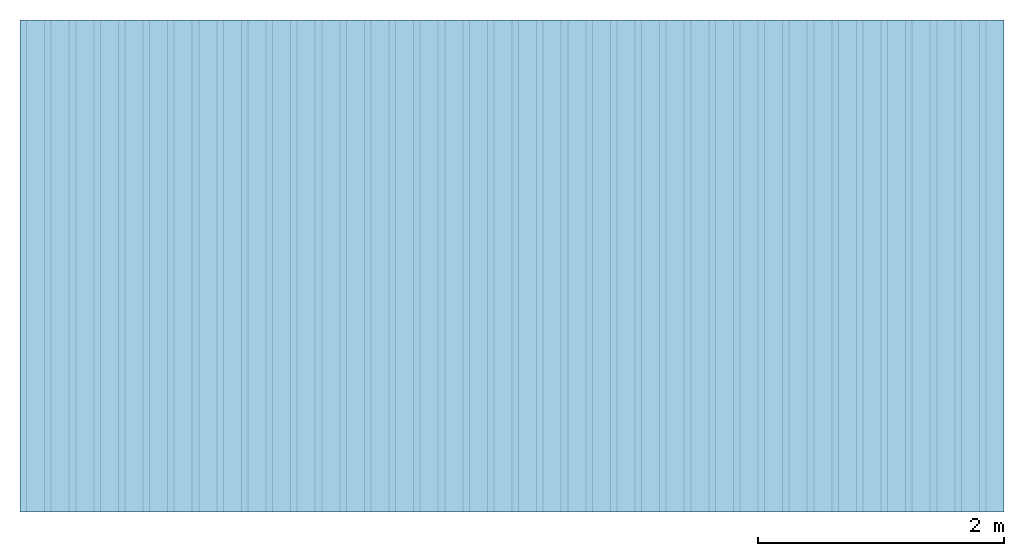
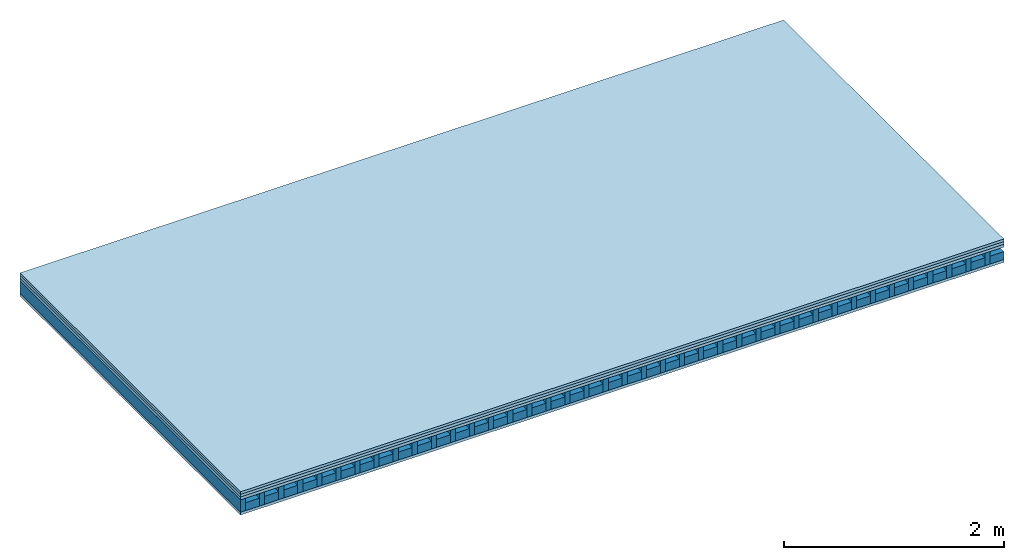
# One storey: 4 plates, 2 members, 1 element without a shape of its own.
"""IFC4 building model written with IfcOpenShell, lengths in metres."""

from ifc_helpers import new_model, si_unit, derived_unit, direction, frame, frame_2d, origin, origin_with_axes, place, context, project, spatial, rectangle, extrude, material, layer, layer_set, type_object, element, aggregate, save


model = new_model("IFC4")

# Units and contexts
plan_context = context("Plan", 3, precision=1e-05, world=origin(), true_north=direction((0.0, 1.0)))
model_context = context("Model", 3, precision=1e-05, world=origin(), true_north=direction((0.0, 1.0)))
ifc_project = project(units=[si_unit("LENGTHUNIT", "METRE"), derived_unit("SOUNDPRESSUREUNIT", [(si_unit("PRESSUREUNIT", "PASCAL", prefix="MICRO"), 0)]), si_unit("ENERGYUNIT", "JOULE", prefix="MEGA"), si_unit("MASSUNIT", "GRAM", prefix="KILO"), derived_unit("THERMALTRANSMITTANCEUNIT", [(si_unit("POWERUNIT", "WATT"), 1), (si_unit("AREAUNIT", "SQUARE_METRE"), -1), (si_unit("THERMODYNAMICTEMPERATUREUNIT", "KELVIN"), -1)]), derived_unit("AREADENSITYUNIT", [(si_unit("MASSUNIT", "GRAM", prefix="KILO"), 1), (si_unit("AREAUNIT", "SQUARE_METRE"), -1)]), derived_unit("USERDEFINED", [(si_unit("ENERGYUNIT", "JOULE", prefix="MEGA"), 1), (si_unit("AREAUNIT", "SQUARE_METRE"), -1)])], contexts=[plan_context, model_context])

# Site, building, storey
site = spatial("IfcSite", under=ifc_project)
building_placement = place(None, origin())
building = spatial("IfcBuilding", under=site, at=building_placement)
storey_placement = place(building_placement, origin())
storey = spatial("IfcBuildingStorey", under=building, at=storey_placement)

# Slab, members, plates
ifc_material_1 = material(Name="P2 ECO", Category="07.015")
ifc_layer_1 = layer(ifc_material_1, 0.028, Name="On-material")
ifc_material_2 = material(Name="EP2, 30mm")
ifc_layer_2 = layer(ifc_material_2, 0.03, Name="Impact sound insulation")
ifc_material_3 = material(Name="box-element sheathing above")
ifc_layer_3 = layer(ifc_material_3, 0.031, Name="Sub-floor")
ifc_layer_4 = layer(None, 0.138, Name="Supporting structure")
ifc_material_4 = material(Name="box-element sheathing below")
ifc_layer_5 = layer(ifc_material_4, 0.031, Name="Lower layer 1")
ifc_layer_set = layer_set([ifc_layer_1, ifc_layer_2, ifc_layer_3, ifc_layer_4, ifc_layer_5])
slab_type = type_object("IfcSlabType", Name="A1462", PredefinedType="NOTDEFINED", material=ifc_layer_set)
slab_placement = place(None, frame((0.0, 0.0, 0.0), z_axis=(0.0, 0.0, -1.0), x_axis=(1.0, 0.0, 0.0)))
slab = element("IfcSlab", 1, at=slab_placement, inside=storey, type_object=slab_type, material=ifc_layer_set, Name="Slab #1")
ifc_material_5 = material(Name="box-element LKE 12")
member_1_placement = place(slab_placement, origin())
member_1 = element("IfcMember", 2, at=member_1_placement, material=ifc_material_5, Name="Supporting structure", context=plan_context, shape_type="SweptSolid", body=[
    extrude(rectangle(XDim=0.054, YDim=0.138, at=frame_2d((0.027, 0.069), x_axis=(1.0, 0.0))), frame((0.0, 4.0, 0.089), z_axis=(0.0, -1.0, 0.0), x_axis=(1.0, 0.0, 0.0)), (0.0, 0.0, 1.0), 4.0),
    extrude(rectangle(XDim=0.054, YDim=0.138, at=frame_2d((0.027, 0.069), x_axis=(1.0, 0.0))), frame((0.2, 4.0, 0.089), z_axis=(0.0, -1.0, 0.0), x_axis=(1.0, 0.0, 0.0)), (0.0, 0.0, 1.0), 4.0),
    extrude(rectangle(XDim=0.054, YDim=0.138, at=frame_2d((0.027, 0.069), x_axis=(1.0, 0.0))), frame((0.4, 4.0, 0.089), z_axis=(0.0, -1.0, 0.0), x_axis=(1.0, 0.0, 0.0)), (0.0, 0.0, 1.0), 4.0),
    extrude(rectangle(XDim=0.054, YDim=0.138, at=frame_2d((0.027, 0.069), x_axis=(1.0, 0.0))), frame((0.6, 4.0, 0.089), z_axis=(0.0, -1.0, 0.0), x_axis=(1.0, 0.0, 0.0)), (0.0, 0.0, 1.0), 4.0),
    extrude(rectangle(XDim=0.054, YDim=0.138, at=frame_2d((0.027, 0.069), x_axis=(1.0, 0.0))), frame((0.8, 4.0, 0.089), z_axis=(0.0, -1.0, 0.0), x_axis=(1.0, 0.0, 0.0)), (0.0, 0.0, 1.0), 4.0),
    extrude(rectangle(XDim=0.054, YDim=0.138, at=frame_2d((0.027, 0.069), x_axis=(1.0, 0.0))), frame((1.0, 4.0, 0.089), z_axis=(0.0, -1.0, 0.0), x_axis=(1.0, 0.0, 0.0)), (0.0, 0.0, 1.0), 4.0),
    extrude(rectangle(XDim=0.054, YDim=0.138, at=frame_2d((0.027, 0.069), x_axis=(1.0, 0.0))), frame((1.2, 4.0, 0.089), z_axis=(0.0, -1.0, 0.0), x_axis=(1.0, 0.0, 0.0)), (0.0, 0.0, 1.0), 4.0),
    extrude(rectangle(XDim=0.054, YDim=0.138, at=frame_2d((0.027, 0.069), x_axis=(1.0, 0.0))), frame((1.4, 4.0, 0.089), z_axis=(0.0, -1.0, 0.0), x_axis=(1.0, 0.0, 0.0)), (0.0, 0.0, 1.0), 4.0),
    extrude(rectangle(XDim=0.054, YDim=0.138, at=frame_2d((0.027, 0.069), x_axis=(1.0, 0.0))), frame((1.6, 4.0, 0.089), z_axis=(0.0, -1.0, 0.0), x_axis=(1.0, 0.0, 0.0)), (0.0, 0.0, 1.0), 4.0),
    extrude(rectangle(XDim=0.054, YDim=0.138, at=frame_2d((0.027, 0.069), x_axis=(1.0, 0.0))), frame((1.8, 4.0, 0.089), z_axis=(0.0, -1.0, 0.0), x_axis=(1.0, 0.0, 0.0)), (0.0, 0.0, 1.0), 4.0),
    extrude(rectangle(XDim=0.054, YDim=0.138, at=frame_2d((0.027, 0.069), x_axis=(1.0, 0.0))), frame((2.0, 4.0, 0.089), z_axis=(0.0, -1.0, 0.0), x_axis=(1.0, 0.0, 0.0)), (0.0, 0.0, 1.0), 4.0),
    extrude(rectangle(XDim=0.054, YDim=0.138, at=frame_2d((0.027, 0.069), x_axis=(1.0, 0.0))), frame((2.2, 4.0, 0.089), z_axis=(0.0, -1.0, 0.0), x_axis=(1.0, 0.0, 0.0)), (0.0, 0.0, 1.0), 4.0),
    extrude(rectangle(XDim=0.054, YDim=0.138, at=frame_2d((0.027, 0.069), x_axis=(1.0, 0.0))), frame((2.4, 4.0, 0.089), z_axis=(0.0, -1.0, 0.0), x_axis=(1.0, 0.0, 0.0)), (0.0, 0.0, 1.0), 4.0),
    extrude(rectangle(XDim=0.054, YDim=0.138, at=frame_2d((0.027, 0.069), x_axis=(1.0, 0.0))), frame((2.6, 4.0, 0.089), z_axis=(0.0, -1.0, 0.0), x_axis=(1.0, 0.0, 0.0)), (0.0, 0.0, 1.0), 4.0),
    extrude(rectangle(XDim=0.054, YDim=0.138, at=frame_2d((0.027, 0.069), x_axis=(1.0, 0.0))), frame((2.8, 4.0, 0.089), z_axis=(0.0, -1.0, 0.0), x_axis=(1.0, 0.0, 0.0)), (0.0, 0.0, 1.0), 4.0),
    extrude(rectangle(XDim=0.054, YDim=0.138, at=frame_2d((0.027, 0.069), x_axis=(1.0, 0.0))), frame((3.0, 4.0, 0.089), z_axis=(0.0, -1.0, 0.0), x_axis=(1.0, 0.0, 0.0)), (0.0, 0.0, 1.0), 4.0),
    extrude(rectangle(XDim=0.054, YDim=0.138, at=frame_2d((0.027, 0.069), x_axis=(1.0, 0.0))), frame((3.2, 4.0, 0.089), z_axis=(0.0, -1.0, 0.0), x_axis=(1.0, 0.0, 0.0)), (0.0, 0.0, 1.0), 4.0),
    extrude(rectangle(XDim=0.054, YDim=0.138, at=frame_2d((0.027, 0.069), x_axis=(1.0, 0.0))), frame((3.4, 4.0, 0.089), z_axis=(0.0, -1.0, 0.0), x_axis=(1.0, 0.0, 0.0)), (0.0, 0.0, 1.0), 4.0),
    extrude(rectangle(XDim=0.054, YDim=0.138, at=frame_2d((0.027, 0.069), x_axis=(1.0, 0.0))), frame((3.6, 4.0, 0.089), z_axis=(0.0, -1.0, 0.0), x_axis=(1.0, 0.0, 0.0)), (0.0, 0.0, 1.0), 4.0),
    extrude(rectangle(XDim=0.054, YDim=0.138, at=frame_2d((0.027, 0.069), x_axis=(1.0, 0.0))), frame((3.8, 4.0, 0.089), z_axis=(0.0, -1.0, 0.0), x_axis=(1.0, 0.0, 0.0)), (0.0, 0.0, 1.0), 4.0),
    extrude(rectangle(XDim=0.054, YDim=0.138, at=frame_2d((0.027, 0.069), x_axis=(1.0, 0.0))), frame((4.0, 4.0, 0.089), z_axis=(0.0, -1.0, 0.0), x_axis=(1.0, 0.0, 0.0)), (0.0, 0.0, 1.0), 4.0),
    extrude(rectangle(XDim=0.054, YDim=0.138, at=frame_2d((0.027, 0.069), x_axis=(1.0, 0.0))), frame((4.2, 4.0, 0.089), z_axis=(0.0, -1.0, 0.0), x_axis=(1.0, 0.0, 0.0)), (0.0, 0.0, 1.0), 4.0),
    extrude(rectangle(XDim=0.054, YDim=0.138, at=frame_2d((0.027, 0.069), x_axis=(1.0, 0.0))), frame((4.4, 4.0, 0.089), z_axis=(0.0, -1.0, 0.0), x_axis=(1.0, 0.0, 0.0)), (0.0, 0.0, 1.0), 4.0),
    extrude(rectangle(XDim=0.054, YDim=0.138, at=frame_2d((0.027, 0.069), x_axis=(1.0, 0.0))), frame((4.6, 4.0, 0.089), z_axis=(0.0, -1.0, 0.0), x_axis=(1.0, 0.0, 0.0)), (0.0, 0.0, 1.0), 4.0),
    extrude(rectangle(XDim=0.054, YDim=0.138, at=frame_2d((0.027, 0.069), x_axis=(1.0, 0.0))), frame((4.8, 4.0, 0.089), z_axis=(0.0, -1.0, 0.0), x_axis=(1.0, 0.0, 0.0)), (0.0, 0.0, 1.0), 4.0),
    extrude(rectangle(XDim=0.054, YDim=0.138, at=frame_2d((0.027, 0.069), x_axis=(1.0, 0.0))), frame((5.0, 4.0, 0.089), z_axis=(0.0, -1.0, 0.0), x_axis=(1.0, 0.0, 0.0)), (0.0, 0.0, 1.0), 4.0),
    extrude(rectangle(XDim=0.054, YDim=0.138, at=frame_2d((0.027, 0.069), x_axis=(1.0, 0.0))), frame((5.2, 4.0, 0.089), z_axis=(0.0, -1.0, 0.0), x_axis=(1.0, 0.0, 0.0)), (0.0, 0.0, 1.0), 4.0),
    extrude(rectangle(XDim=0.054, YDim=0.138, at=frame_2d((0.027, 0.069), x_axis=(1.0, 0.0))), frame((5.4, 4.0, 0.089), z_axis=(0.0, -1.0, 0.0), x_axis=(1.0, 0.0, 0.0)), (0.0, 0.0, 1.0), 4.0),
    extrude(rectangle(XDim=0.054, YDim=0.138, at=frame_2d((0.027, 0.069), x_axis=(1.0, 0.0))), frame((5.6, 4.0, 0.089), z_axis=(0.0, -1.0, 0.0), x_axis=(1.0, 0.0, 0.0)), (0.0, 0.0, 1.0), 4.0),
    extrude(rectangle(XDim=0.054, YDim=0.138, at=frame_2d((0.027, 0.069), x_axis=(1.0, 0.0))), frame((5.8, 4.0, 0.089), z_axis=(0.0, -1.0, 0.0), x_axis=(1.0, 0.0, 0.0)), (0.0, 0.0, 1.0), 4.0),
    extrude(rectangle(XDim=0.054, YDim=0.138, at=frame_2d((0.027, 0.069), x_axis=(1.0, 0.0))), frame((6.0, 4.0, 0.089), z_axis=(0.0, -1.0, 0.0), x_axis=(1.0, 0.0, 0.0)), (0.0, 0.0, 1.0), 4.0),
    extrude(rectangle(XDim=0.054, YDim=0.138, at=frame_2d((0.027, 0.069), x_axis=(1.0, 0.0))), frame((6.2, 4.0, 0.089), z_axis=(0.0, -1.0, 0.0), x_axis=(1.0, 0.0, 0.0)), (0.0, 0.0, 1.0), 4.0),
    extrude(rectangle(XDim=0.054, YDim=0.138, at=frame_2d((0.027, 0.069), x_axis=(1.0, 0.0))), frame((6.4, 4.0, 0.089), z_axis=(0.0, -1.0, 0.0), x_axis=(1.0, 0.0, 0.0)), (0.0, 0.0, 1.0), 4.0),
    extrude(rectangle(XDim=0.054, YDim=0.138, at=frame_2d((0.027, 0.069), x_axis=(1.0, 0.0))), frame((6.6, 4.0, 0.089), z_axis=(0.0, -1.0, 0.0), x_axis=(1.0, 0.0, 0.0)), (0.0, 0.0, 1.0), 4.0),
    extrude(rectangle(XDim=0.054, YDim=0.138, at=frame_2d((0.027, 0.069), x_axis=(1.0, 0.0))), frame((6.8, 4.0, 0.089), z_axis=(0.0, -1.0, 0.0), x_axis=(1.0, 0.0, 0.0)), (0.0, 0.0, 1.0), 4.0),
    extrude(rectangle(XDim=0.054, YDim=0.138, at=frame_2d((0.027, 0.069), x_axis=(1.0, 0.0))), frame((7.0, 4.0, 0.089), z_axis=(0.0, -1.0, 0.0), x_axis=(1.0, 0.0, 0.0)), (0.0, 0.0, 1.0), 4.0),
    extrude(rectangle(XDim=0.054, YDim=0.138, at=frame_2d((0.027, 0.069), x_axis=(1.0, 0.0))), frame((7.2, 4.0, 0.089), z_axis=(0.0, -1.0, 0.0), x_axis=(1.0, 0.0, 0.0)), (0.0, 0.0, 1.0), 4.0),
    extrude(rectangle(XDim=0.054, YDim=0.138, at=frame_2d((0.027, 0.069), x_axis=(1.0, 0.0))), frame((7.4, 4.0, 0.089), z_axis=(0.0, -1.0, 0.0), x_axis=(1.0, 0.0, 0.0)), (0.0, 0.0, 1.0), 4.0),
    extrude(rectangle(XDim=0.054, YDim=0.138, at=frame_2d((0.027, 0.069), x_axis=(1.0, 0.0))), frame((7.6, 4.0, 0.089), z_axis=(0.0, -1.0, 0.0), x_axis=(1.0, 0.0, 0.0)), (0.0, 0.0, 1.0), 4.0),
    extrude(rectangle(XDim=0.054, YDim=0.138, at=frame_2d((0.027, 0.069), x_axis=(1.0, 0.0))), frame((7.8, 4.0, 0.089), z_axis=(0.0, -1.0, 0.0), x_axis=(1.0, 0.0, 0.0)), (0.0, 0.0, 1.0), 4.0),
])
ifc_material_6 = material(Name="Damper and limestone LKE 12")
member_2_placement = place(slab_placement, origin())
member_2 = element("IfcMember", 3, at=member_2_placement, material=ifc_material_6, Name="in supporting structure", context=plan_context, shape_type="SweptSolid", body=[
    extrude(rectangle(XDim=0.146, YDim=0.088, at=frame_2d((0.073, 0.044), x_axis=(1.0, 0.0))), frame((0.054, 4.0, 0.139), z_axis=(0.0, -1.0, 0.0), x_axis=(1.0, 0.0, 0.0)), (0.0, 0.0, 1.0), 4.0),
    extrude(rectangle(XDim=0.146, YDim=0.088, at=frame_2d((0.073, 0.044), x_axis=(1.0, 0.0))), frame((0.254, 4.0, 0.139), z_axis=(0.0, -1.0, 0.0), x_axis=(1.0, 0.0, 0.0)), (0.0, 0.0, 1.0), 4.0),
    extrude(rectangle(XDim=0.146, YDim=0.088, at=frame_2d((0.073, 0.044), x_axis=(1.0, 0.0))), frame((0.454, 4.0, 0.139), z_axis=(0.0, -1.0, 0.0), x_axis=(1.0, 0.0, 0.0)), (0.0, 0.0, 1.0), 4.0),
    extrude(rectangle(XDim=0.146, YDim=0.088, at=frame_2d((0.073, 0.044), x_axis=(1.0, 0.0))), frame((0.654, 4.0, 0.139), z_axis=(0.0, -1.0, 0.0), x_axis=(1.0, 0.0, 0.0)), (0.0, 0.0, 1.0), 4.0),
    extrude(rectangle(XDim=0.146, YDim=0.088, at=frame_2d((0.073, 0.044), x_axis=(1.0, 0.0))), frame((0.854, 4.0, 0.139), z_axis=(0.0, -1.0, 0.0), x_axis=(1.0, 0.0, 0.0)), (0.0, 0.0, 1.0), 4.0),
    extrude(rectangle(XDim=0.146, YDim=0.088, at=frame_2d((0.073, 0.044), x_axis=(1.0, 0.0))), frame((1.054, 4.0, 0.139), z_axis=(0.0, -1.0, 0.0), x_axis=(1.0, 0.0, 0.0)), (0.0, 0.0, 1.0), 4.0),
    extrude(rectangle(XDim=0.146, YDim=0.088, at=frame_2d((0.073, 0.044), x_axis=(1.0, 0.0))), frame((1.254, 4.0, 0.139), z_axis=(0.0, -1.0, 0.0), x_axis=(1.0, 0.0, 0.0)), (0.0, 0.0, 1.0), 4.0),
    extrude(rectangle(XDim=0.146, YDim=0.088, at=frame_2d((0.073, 0.044), x_axis=(1.0, 0.0))), frame((1.454, 4.0, 0.139), z_axis=(0.0, -1.0, 0.0), x_axis=(1.0, 0.0, 0.0)), (0.0, 0.0, 1.0), 4.0),
    extrude(rectangle(XDim=0.146, YDim=0.088, at=frame_2d((0.073, 0.044), x_axis=(1.0, 0.0))), frame((1.654, 4.0, 0.139), z_axis=(0.0, -1.0, 0.0), x_axis=(1.0, 0.0, 0.0)), (0.0, 0.0, 1.0), 4.0),
    extrude(rectangle(XDim=0.146, YDim=0.088, at=frame_2d((0.073, 0.044), x_axis=(1.0, 0.0))), frame((1.854, 4.0, 0.139), z_axis=(0.0, -1.0, 0.0), x_axis=(1.0, 0.0, 0.0)), (0.0, 0.0, 1.0), 4.0),
    extrude(rectangle(XDim=0.146, YDim=0.088, at=frame_2d((0.073, 0.044), x_axis=(1.0, 0.0))), frame((2.054, 4.0, 0.139), z_axis=(0.0, -1.0, 0.0), x_axis=(1.0, 0.0, 0.0)), (0.0, 0.0, 1.0), 4.0),
    extrude(rectangle(XDim=0.146, YDim=0.088, at=frame_2d((0.073, 0.044), x_axis=(1.0, 0.0))), frame((2.254, 4.0, 0.139), z_axis=(0.0, -1.0, 0.0), x_axis=(1.0, 0.0, 0.0)), (0.0, 0.0, 1.0), 4.0),
    extrude(rectangle(XDim=0.146, YDim=0.088, at=frame_2d((0.073, 0.044), x_axis=(1.0, 0.0))), frame((2.454, 4.0, 0.139), z_axis=(0.0, -1.0, 0.0), x_axis=(1.0, 0.0, 0.0)), (0.0, 0.0, 1.0), 4.0),
    extrude(rectangle(XDim=0.146, YDim=0.088, at=frame_2d((0.073, 0.044), x_axis=(1.0, 0.0))), frame((2.654, 4.0, 0.139), z_axis=(0.0, -1.0, 0.0), x_axis=(1.0, 0.0, 0.0)), (0.0, 0.0, 1.0), 4.0),
    extrude(rectangle(XDim=0.146, YDim=0.088, at=frame_2d((0.073, 0.044), x_axis=(1.0, 0.0))), frame((2.854, 4.0, 0.139), z_axis=(0.0, -1.0, 0.0), x_axis=(1.0, 0.0, 0.0)), (0.0, 0.0, 1.0), 4.0),
    extrude(rectangle(XDim=0.146, YDim=0.088, at=frame_2d((0.073, 0.044), x_axis=(1.0, 0.0))), frame((3.054, 4.0, 0.139), z_axis=(0.0, -1.0, 0.0), x_axis=(1.0, 0.0, 0.0)), (0.0, 0.0, 1.0), 4.0),
    extrude(rectangle(XDim=0.146, YDim=0.088, at=frame_2d((0.073, 0.044), x_axis=(1.0, 0.0))), frame((3.254, 4.0, 0.139), z_axis=(0.0, -1.0, 0.0), x_axis=(1.0, 0.0, 0.0)), (0.0, 0.0, 1.0), 4.0),
    extrude(rectangle(XDim=0.146, YDim=0.088, at=frame_2d((0.073, 0.044), x_axis=(1.0, 0.0))), frame((3.454, 4.0, 0.139), z_axis=(0.0, -1.0, 0.0), x_axis=(1.0, 0.0, 0.0)), (0.0, 0.0, 1.0), 4.0),
    extrude(rectangle(XDim=0.146, YDim=0.088, at=frame_2d((0.073, 0.044), x_axis=(1.0, 0.0))), frame((3.654, 4.0, 0.139), z_axis=(0.0, -1.0, 0.0), x_axis=(1.0, 0.0, 0.0)), (0.0, 0.0, 1.0), 4.0),
    extrude(rectangle(XDim=0.146, YDim=0.088, at=frame_2d((0.073, 0.044), x_axis=(1.0, 0.0))), frame((3.854, 4.0, 0.139), z_axis=(0.0, -1.0, 0.0), x_axis=(1.0, 0.0, 0.0)), (0.0, 0.0, 1.0), 4.0),
    extrude(rectangle(XDim=0.146, YDim=0.088, at=frame_2d((0.073, 0.044), x_axis=(1.0, 0.0))), frame((4.054, 4.0, 0.139), z_axis=(0.0, -1.0, 0.0), x_axis=(1.0, 0.0, 0.0)), (0.0, 0.0, 1.0), 4.0),
    extrude(rectangle(XDim=0.146, YDim=0.088, at=frame_2d((0.073, 0.044), x_axis=(1.0, 0.0))), frame((4.254, 4.0, 0.139), z_axis=(0.0, -1.0, 0.0), x_axis=(1.0, 0.0, 0.0)), (0.0, 0.0, 1.0), 4.0),
    extrude(rectangle(XDim=0.146, YDim=0.088, at=frame_2d((0.073, 0.044), x_axis=(1.0, 0.0))), frame((4.454, 4.0, 0.139), z_axis=(0.0, -1.0, 0.0), x_axis=(1.0, 0.0, 0.0)), (0.0, 0.0, 1.0), 4.0),
    extrude(rectangle(XDim=0.146, YDim=0.088, at=frame_2d((0.073, 0.044), x_axis=(1.0, 0.0))), frame((4.654, 4.0, 0.139), z_axis=(0.0, -1.0, 0.0), x_axis=(1.0, 0.0, 0.0)), (0.0, 0.0, 1.0), 4.0),
    extrude(rectangle(XDim=0.146, YDim=0.088, at=frame_2d((0.073, 0.044), x_axis=(1.0, 0.0))), frame((4.854, 4.0, 0.139), z_axis=(0.0, -1.0, 0.0), x_axis=(1.0, 0.0, 0.0)), (0.0, 0.0, 1.0), 4.0),
    extrude(rectangle(XDim=0.146, YDim=0.088, at=frame_2d((0.073, 0.044), x_axis=(1.0, 0.0))), frame((5.054, 4.0, 0.139), z_axis=(0.0, -1.0, 0.0), x_axis=(1.0, 0.0, 0.0)), (0.0, 0.0, 1.0), 4.0),
    extrude(rectangle(XDim=0.146, YDim=0.088, at=frame_2d((0.073, 0.044), x_axis=(1.0, 0.0))), frame((5.254, 4.0, 0.139), z_axis=(0.0, -1.0, 0.0), x_axis=(1.0, 0.0, 0.0)), (0.0, 0.0, 1.0), 4.0),
    extrude(rectangle(XDim=0.146, YDim=0.088, at=frame_2d((0.073, 0.044), x_axis=(1.0, 0.0))), frame((5.454, 4.0, 0.139), z_axis=(0.0, -1.0, 0.0), x_axis=(1.0, 0.0, 0.0)), (0.0, 0.0, 1.0), 4.0),
    extrude(rectangle(XDim=0.146, YDim=0.088, at=frame_2d((0.073, 0.044), x_axis=(1.0, 0.0))), frame((5.654, 4.0, 0.139), z_axis=(0.0, -1.0, 0.0), x_axis=(1.0, 0.0, 0.0)), (0.0, 0.0, 1.0), 4.0),
    extrude(rectangle(XDim=0.146, YDim=0.088, at=frame_2d((0.073, 0.044), x_axis=(1.0, 0.0))), frame((5.854, 4.0, 0.139), z_axis=(0.0, -1.0, 0.0), x_axis=(1.0, 0.0, 0.0)), (0.0, 0.0, 1.0), 4.0),
    extrude(rectangle(XDim=0.146, YDim=0.088, at=frame_2d((0.073, 0.044), x_axis=(1.0, 0.0))), frame((6.054, 4.0, 0.139), z_axis=(0.0, -1.0, 0.0), x_axis=(1.0, 0.0, 0.0)), (0.0, 0.0, 1.0), 4.0),
    extrude(rectangle(XDim=0.146, YDim=0.088, at=frame_2d((0.073, 0.044), x_axis=(1.0, 0.0))), frame((6.254, 4.0, 0.139), z_axis=(0.0, -1.0, 0.0), x_axis=(1.0, 0.0, 0.0)), (0.0, 0.0, 1.0), 4.0),
    extrude(rectangle(XDim=0.146, YDim=0.088, at=frame_2d((0.073, 0.044), x_axis=(1.0, 0.0))), frame((6.454, 4.0, 0.139), z_axis=(0.0, -1.0, 0.0), x_axis=(1.0, 0.0, 0.0)), (0.0, 0.0, 1.0), 4.0),
    extrude(rectangle(XDim=0.146, YDim=0.088, at=frame_2d((0.073, 0.044), x_axis=(1.0, 0.0))), frame((6.654, 4.0, 0.139), z_axis=(0.0, -1.0, 0.0), x_axis=(1.0, 0.0, 0.0)), (0.0, 0.0, 1.0), 4.0),
    extrude(rectangle(XDim=0.146, YDim=0.088, at=frame_2d((0.073, 0.044), x_axis=(1.0, 0.0))), frame((6.854, 4.0, 0.139), z_axis=(0.0, -1.0, 0.0), x_axis=(1.0, 0.0, 0.0)), (0.0, 0.0, 1.0), 4.0),
    extrude(rectangle(XDim=0.146, YDim=0.088, at=frame_2d((0.073, 0.044), x_axis=(1.0, 0.0))), frame((7.054, 4.0, 0.139), z_axis=(0.0, -1.0, 0.0), x_axis=(1.0, 0.0, 0.0)), (0.0, 0.0, 1.0), 4.0),
    extrude(rectangle(XDim=0.146, YDim=0.088, at=frame_2d((0.073, 0.044), x_axis=(1.0, 0.0))), frame((7.254, 4.0, 0.139), z_axis=(0.0, -1.0, 0.0), x_axis=(1.0, 0.0, 0.0)), (0.0, 0.0, 1.0), 4.0),
    extrude(rectangle(XDim=0.146, YDim=0.088, at=frame_2d((0.073, 0.044), x_axis=(1.0, 0.0))), frame((7.454, 4.0, 0.139), z_axis=(0.0, -1.0, 0.0), x_axis=(1.0, 0.0, 0.0)), (0.0, 0.0, 1.0), 4.0),
    extrude(rectangle(XDim=0.146, YDim=0.088, at=frame_2d((0.073, 0.044), x_axis=(1.0, 0.0))), frame((7.654, 4.0, 0.139), z_axis=(0.0, -1.0, 0.0), x_axis=(1.0, 0.0, 0.0)), (0.0, 0.0, 1.0), 4.0),
    extrude(rectangle(XDim=0.146, YDim=0.088, at=frame_2d((0.073, 0.044), x_axis=(1.0, 0.0))), frame((7.854, 4.0, 0.139), z_axis=(0.0, -1.0, 0.0), x_axis=(1.0, 0.0, 0.0)), (0.0, 0.0, 1.0), 4.0),
])
plate_1_placement = place(slab_placement, origin())
plate_1 = element("IfcPlate", 4, at=plate_1_placement, material=ifc_material_1, Name="On-material", context=plan_context, shape_type="SweptSolid", body=[
    extrude(rectangle(XDim=8.0, YDim=4.0, at=frame_2d((4.0, 2.0), x_axis=(1.0, 0.0))), origin_with_axes(), (0.0, 0.0, 1.0), 0.028),
])
plate_2_placement = place(slab_placement, origin())
plate_2 = element("IfcPlate", 5, at=plate_2_placement, material=ifc_material_2, Name="Impact sound insulation", context=plan_context, shape_type="SweptSolid", body=[
    extrude(rectangle(XDim=8.0, YDim=4.0, at=frame_2d((4.0, 2.0), x_axis=(1.0, 0.0))), frame((0.0, 0.0, 0.028), z_axis=(0.0, 0.0, 1.0), x_axis=(1.0, 0.0, 0.0)), (0.0, 0.0, 1.0), 0.03),
])
plate_3_placement = place(slab_placement, origin())
plate_3 = element("IfcPlate", 6, at=plate_3_placement, material=ifc_material_3, Name="Sub-floor", context=plan_context, shape_type="SweptSolid", body=[
    extrude(rectangle(XDim=8.0, YDim=4.0, at=frame_2d((4.0, 2.0), x_axis=(1.0, 0.0))), frame((0.0, 0.0, 0.058), z_axis=(0.0, 0.0, 1.0), x_axis=(1.0, 0.0, 0.0)), (0.0, 0.0, 1.0), 0.031),
])
plate_4_placement = place(slab_placement, origin())
plate_4 = element("IfcPlate", 7, at=plate_4_placement, material=ifc_material_4, Name="Lower layer 1", context=plan_context, shape_type="SweptSolid", body=[
    extrude(rectangle(XDim=8.0, YDim=4.0, at=frame_2d((4.0, 2.0), x_axis=(1.0, 0.0))), frame((0.0, 0.0, 0.227), z_axis=(0.0, 0.0, 1.0), x_axis=(1.0, 0.0, 0.0)), (0.0, 0.0, 1.0), 0.031),
])
aggregate(slab, [plate_1, plate_2, plate_3, member_1, member_2, plate_4])

save(model, "model.ifc")
